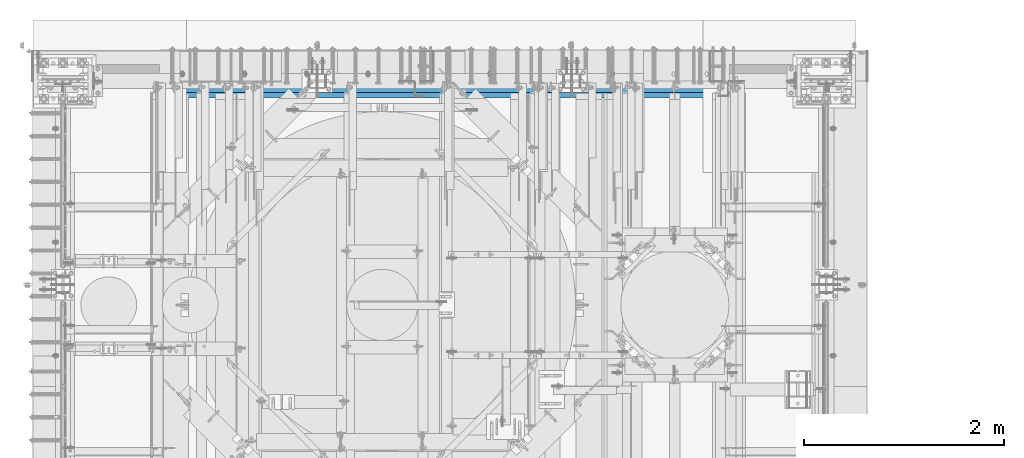
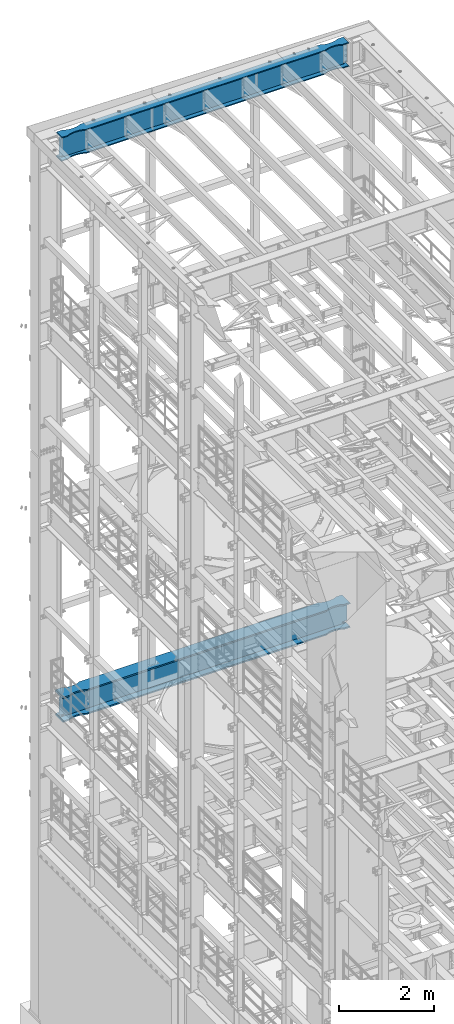
# One storey, part 1067 of 1876: 2 beams, 2 elements without a shape of their own.
"""IFC2X3 building model written with IfcOpenShell, lengths in millimetres."""

import ifcopenshell
import ifcopenshell.guid

model = None  # the IFC model being written
_history = None  # IfcOwnerHistory: only IFC2X3 demands one
_inside = {}  # id of a spatial element -> (the spatial element, [elements in it])
_under = {}  # id of a project, library or spatial element -> (it, [spatial elements below it])
_declared = {}  # id of a project -> (the project, [libraries it declares])
_typed = {}  # id of a type object -> (the type object, [elements of that type])
_made_of = {}  # id of a material, layer set ... -> (it, [elements and type objects made of it])


def new_model(schema):
    """Start an empty IFC model of exactly this schema.

    Asked for "IFC4X3", IfcOpenShell would pick the latest addendum, in which some entities
    have other attributes; the version numbers below select the first issue.
    IFC2X3 requires an IfcOwnerHistory on every rooted entity: one is made here for all.
    """
    global model, _history
    if schema == "IFC4X3":
        model = ifcopenshell.file(schema_version=(4, 3, 0, 0))
    else:
        model = ifcopenshell.file(schema=schema)
    _inside.clear()
    _under.clear()
    _declared.clear()
    _typed.clear()
    _made_of.clear()
    _history = None
    if model.schema == "IFC2X3":
        org = make("IfcOrganization", Name="unknown")
        user = make(
            "IfcPersonAndOrganization",
            ThePerson=make("IfcPerson", FamilyName="unknown"),
            TheOrganization=org,
        )
        app = make(
            "IfcApplication",
            ApplicationDeveloper=org,
            Version="unknown",
            ApplicationFullName="unknown",
            ApplicationIdentifier="unknown",
        )
        _history = make(
            "IfcOwnerHistory",
            OwningUser=user,
            OwningApplication=app,
            ChangeAction="ADDED",
            CreationDate=0,
        )
    return model


def make(cls, **values):
    """One entity of the class cls with the attributes given. An attribute that is None is left unset."""
    return model.create_entity(
        cls, **{name: value for name, value in values.items() if value is not None}
    )


def rooted(cls, **values):
    """An entity with a GlobalId (a new one), such as an element, a storey or a relation."""
    return make(cls, GlobalId=ifcopenshell.guid.new(), OwnerHistory=_history, **values)


def si_unit(unit_type, name, prefix=None):
    """IfcSIUnit, for example si_unit("LENGTHUNIT", "METRE", prefix="MILLI")."""
    return make("IfcSIUnit", UnitType=unit_type, Prefix=prefix, Name=name)


def assignment(units):
    """IfcUnitAssignment: the units of a project."""
    return None if units is None else make("IfcUnitAssignment", Units=units)


def point(xyz):
    """IfcCartesianPoint."""
    return None if xyz is None else make("IfcCartesianPoint", Coordinates=xyz)


def direction(xyz):
    """IfcDirection."""
    return None if xyz is None else make("IfcDirection", DirectionRatios=xyz)


def frame(location, z_axis=None, x_axis=None):
    """IfcAxis2Placement3D, a coordinate frame: its origin and axes. An axis left out is left unset."""
    return make(
        "IfcAxis2Placement3D",
        Location=point(location),
        Axis=direction(z_axis),
        RefDirection=direction(x_axis),
    )


def origin_with_axes():
    """The frame at (0, 0, 0) with the z axis (0, 0, 1) and the x axis (1, 0, 0) written out."""
    return frame((0.0, 0.0, 0.0), z_axis=(0.0, 0.0, 1.0), x_axis=(1.0, 0.0, 0.0))


def place(relative_to, where):
    """IfcLocalPlacement: puts the frame where relative to a parent placement (None: the world)."""
    return make(
        "IfcLocalPlacement", PlacementRelTo=relative_to, RelativePlacement=where
    )


def context(
    kind, dimensions, precision=None, world=None, true_north=None, identifier=None
):
    """IfcGeometricRepresentationContext, for example the 3D "Model" context."""
    return make(
        "IfcGeometricRepresentationContext",
        ContextIdentifier=identifier,
        ContextType=kind,
        CoordinateSpaceDimension=dimensions,
        Precision=precision,
        WorldCoordinateSystem=world,
        TrueNorth=true_north,
    )


def subcontext(parent, identifier, kind, view, scale=None):
    """IfcGeometricRepresentationSubContext, for example "Body" below "Model"."""
    return make(
        "IfcGeometricRepresentationSubContext",
        ContextIdentifier=identifier,
        ContextType=kind,
        ParentContext=parent,
        TargetScale=scale,
        TargetView=view,
    )


def project(units=None, contexts=None):
    """IfcProject with its units and contexts."""
    return rooted(
        "IfcProject",
        Name="project",
        RepresentationContexts=contexts,
        UnitsInContext=assignment(units),
    )


def spatial(cls, under=None, at=None, **own):
    """A site, building, storey or space (cls), placed at a placement, below another one or the project."""
    s = rooted(cls, ObjectPlacement=at, **own)
    if under is not None:
        _under.setdefault(under.id(), (under, []))[1].append(s)
    return s


def faces_of(points, faces, orient=None, outer=None):
    """IfcFace entities. A face is a list of loops; a loop is a list of indices into points, from 0.

    orient and outer hold one flag for each loop. By default every Orientation is true, the
    first loop of a face is its IfcFaceOuterBound and the others are IfcFaceBound.
    """
    made = []
    for i, loops in enumerate(faces):
        bounds = []
        for j, loop in enumerate(loops):
            is_outer = j == 0 if outer is None else outer[i][j]
            bounds.append(
                make(
                    "IfcFaceOuterBound" if is_outer else "IfcFaceBound",
                    Bound=make("IfcPolyLoop", Polygon=[points[k] for k in loop]),
                    Orientation=True if orient is None else orient[i][j],
                )
            )
        made.append(make("IfcFace", Bounds=bounds))
    return made


def faceted_brep(points, faces, orient=None, outer=None, voids=None):
    """IfcFacetedBrep: a solid bounded by flat faces; with voids (closed shells), ...WithVoids."""
    shared = [point(p) for p in points]
    hull = make("IfcClosedShell", CfsFaces=faces_of(shared, faces, orient, outer))
    if voids is None:
        return make("IfcFacetedBrep", Outer=hull)
    return make(
        "IfcFacetedBrepWithVoids",
        Outer=hull,
        Voids=[
            make(cls, CfsFaces=faces_of(shared, fs, o, b)) for cls, fs, o, b in voids
        ],
    )


def shape(context_of_items, identifier, shape_type, items):
    """IfcShapeRepresentation: the items that make up one representation, for example the "Body"."""
    return make(
        "IfcShapeRepresentation",
        ContextOfItems=context_of_items,
        RepresentationIdentifier=identifier,
        RepresentationType=shape_type,
        Items=items,
    )


def material(Name=None, Category=None):
    """IfcMaterial."""
    return make("IfcMaterial", Name=Name, Category=Category)


def made_of(thing, what):
    """Note that an element or type object is made of a material, layer set ...; save() writes the relation."""
    if what is not None:
        _made_of.setdefault(what.id(), (what, []))[1].append(thing)
    return thing


def type_object(cls, material=None, **own):
    """A type object (cls), such as IfcWallType, which elements share."""
    return made_of(rooted(cls, **own), material)


def element(
    cls,
    number,
    at=None,
    inside=None,
    cuts=None,
    type_object=None,
    material=None,
    context=None,
    identifier="Body",
    shape_type=None,
    held_by="IfcProductDefinitionShape",
    body=None,
    shapes=None,
    **own,
):
    """One element of the class cls, such as IfcWall. Its Tag is "e" and its number.

    at: its placement. inside: the storey or other place that contains it. cuts: it is an
    opening in that element (IfcRelVoidsElement). A single representation is given by context,
    identifier, shape_type and body (its items); several are given by shapes. held_by: the class
    of the entity that holds the representations. save() writes the other relations.
    """
    e = rooted(cls, Tag="e%d" % number, ObjectPlacement=at, **own)
    if body is not None:
        shapes = [shape(context, identifier, shape_type, body)]
    if shapes is not None:
        e.Representation = make(held_by, Representations=shapes)
    if inside is not None:
        _inside.setdefault(inside.id(), (inside, []))[1].append(e)
    if cuts is not None:
        rooted(
            "IfcRelVoidsElement", RelatingBuildingElement=cuts, RelatedOpeningElement=e
        )
    if type_object is not None:
        _typed.setdefault(type_object.id(), (type_object, []))[1].append(e)
    return made_of(e, material)


def aggregate(whole, parts):
    """IfcRelAggregates: a whole, such as a stair, and the parts it consists of."""
    return rooted("IfcRelAggregates", RelatingObject=whole, RelatedObjects=parts)


def save(model, path):
    """Write the relations noted so far, then the file.

    IfcRelAggregates (storeys below a building ...), IfcRelContainedInSpatialStructure (elements
    in a storey), IfcRelDefinesByType, IfcRelAssociatesMaterial and IfcRelDeclares: one each for
    every whole, place, type object, material and project.
    """
    for whole, parts in _under.values():
        aggregate(whole, parts)
    for where, things in _inside.values():
        rooted(
            "IfcRelContainedInSpatialStructure",
            RelatedElements=things,
            RelatingStructure=where,
        )
    for kind, things in _typed.values():
        rooted("IfcRelDefinesByType", RelatedObjects=things, RelatingType=kind)
    for what, things in _made_of.values():
        rooted("IfcRelAssociatesMaterial", RelatedObjects=things, RelatingMaterial=what)
    for by, libraries in _declared.values():
        rooted("IfcRelDeclares", RelatingContext=by, RelatedDefinitions=libraries)
    model.write(path)


model = new_model("IFC2X3")

# Units and contexts
model_context = context("Model", 3, precision=1e-05, world=origin_with_axes())
body_context = subcontext(model_context, "Body", "Model", "MODEL_VIEW")
ifc_project = project(units=[si_unit("LENGTHUNIT", "METRE", prefix="MILLI"), si_unit("AREAUNIT", "SQUARE_METRE"), si_unit("VOLUMEUNIT", "CUBIC_METRE"), si_unit("MASSUNIT", "GRAM", prefix="KILO"), si_unit("TIMEUNIT", "SECOND"), si_unit("PLANEANGLEUNIT", "RADIAN"), si_unit("SOLIDANGLEUNIT", "STERADIAN"), si_unit("THERMODYNAMICTEMPERATUREUNIT", "DEGREE_CELSIUS"), si_unit("LUMINOUSINTENSITYUNIT", "LUMEN")], contexts=[model_context])

# Site, building, storey
site_placement = place(None, origin_with_axes())
site = spatial("IfcSite", under=ifc_project, at=site_placement, CompositionType="ELEMENT")
building_placement = place(site_placement, origin_with_axes())
building = spatial("IfcBuilding", under=site, at=building_placement, Name="Undefined", CompositionType="ELEMENT")
storey_placement = place(building_placement, origin_with_axes())
storey = spatial("IfcBuildingStorey", under=building, at=storey_placement, Name="Undefined", CompositionType="ELEMENT", Elevation=0.0)

# Assembly, beam
assembly_1_placement = place(storey_placement, origin_with_axes())
assembly_1 = element("IfcElementAssembly", 1, at=assembly_1_placement, inside=storey, Name="BEAM", AssemblyPlace="NOTDEFINED", PredefinedType="RIGID_FRAME")
ifc_material = material(Name="STEEL/A992")
beam_type_1 = type_object("IfcBeamType", Name="W24X103", PredefinedType="NOTDEFINED")
beam_1_placement = place(assembly_1_placement, frame((0.0, 13716.0, 22244.05), z_axis=(0.0, 0.0, 1.0), x_axis=(1.0, 0.0, 0.0)))
beam_1 = element("IfcBeam", 2, at=beam_1_placement, type_object=beam_type_1, material=ifc_material, Name="BEAM", ObjectType="W24X103", context=body_context, shape_type="Brep", body=[
    faceted_brep([(7310.4375, 7.14374999999927, 250.825000000001), (7318.375, -7.14374999999927, 250.825000000001), (7318.375, -7.14374999999927, -250.825000000001), (7310.4375, 7.14374999999927, -250.825000000001), (301.625, -7.14374999999927, 250.825000000001), (309.5625, 7.14374999999927, 250.825000000001), (309.5625, 7.14374999999927, -250.825000000001), (301.625, -7.14374999999927, -250.825000000001), (7031.26184334843, -69.8863852197028, -285.75), (7031.26184334843, -69.8863852197028, -311.150000000001), (7113.70085269938, -88.8999885500325, -311.150000000001), (7113.70085269938, -88.8999885500325, -285.75), (6946.89999522536, -63.4999969110422, -285.75), (6946.89999522536, -63.4999969110422, -311.150000000001), (6862.53814723751, -69.886387005964, -285.75), (6862.53814723751, -69.886387005964, -311.150000000001), (6780.09913828916, -88.8999920818405, -285.75), (6780.09913828916, -88.8999920818405, -311.150000000001), (6730.99999123786, -114.3, -285.75), (6730.99999123786, -114.3, -311.150000000001), (889.000008761879, -114.300009625518, -285.75), (889.000008761879, -114.3, -311.150000000001), (6730.99999123786, -114.3, 285.75), (6730.99999123786, -114.3, 311.150000000001), (889.000008761879, -114.300009625518, 311.150000000001), (889.000008761879, -114.3, 285.75), (6780.09913828916, -88.8999920818405, 285.75), (6780.09913828916, -88.8999920818405, 311.150000000001), (6862.53814723751, -69.886387005964, 285.75), (6862.53814723751, -69.886387005964, 311.150000000001), (6946.89999522536, -63.4999969110422, 285.75), (6946.89999522536, -63.4999969110422, 311.150000000001), (7031.26184334843, -69.8863852197028, 285.75), (7031.26184334843, -69.8863852197028, 311.150000000001), (7113.70085269938, -88.8999885500325, 285.75), (7113.70085269938, -88.8999885500325, 311.150000000001), (7162.79999999982, -114.299985144468, 311.150000000001), (7162.79999999982, -114.3, 285.75), (7318.375, -114.3, 285.75), (7303.71041369173, -114.299998599709, 311.150000000001), (7269.91500317383, -7.14375000000018, -285.35299987793), (7269.91500317383, 7.14375000000018, -285.35299987793), (7234.44274885072, 7.14375000000018, -269.000062630286), (7234.44274885072, -7.14375000000018, -269.000062630286), (7230.55254094452, 7.14375000000018, -265.703842989446), (7230.55254094452, -7.14375000000018, -265.703842989446), (7228.91987519741, 7.14375000000018, -260.873399528195), (7228.91987519741, -7.14375000000018, -260.873399528195), (7230.01261637614, 7.14375000000018, -255.89296800167), (7230.01261637614, -7.14375000000018, -255.89296800167), (7233.51762316711, 7.14375000000018, -252.189765486371), (7233.51762316711, -7.14375000000018, -252.189765486371), (7238.43048349907, 7.14375000000018, -250.825000000001), (7238.43048349907, -7.14375000000018, -250.825000000001), (7239.26548546451, 7.14375000000018, 250.825000000001), (7239.26548546451, -7.14375000000018, 250.825000000001), (7234.35262519576, 7.14375000000018, 252.189765448315), (7234.35262519576, -7.14375000000018, 252.189765448315), (7230.84761841062, 7.14375000000018, 255.892967871263), (7230.84761841062, -7.14375000000018, 255.892967871263), (7229.75487715069, 7.14375000000018, 260.873399307191), (7229.75487715069, -7.14375000000018, 260.873399307191), (7231.38754274408, 7.14375000000018, 265.703842745359), (7231.38754274408, -7.14375000000018, 265.703842745359), (7235.27775048114, 7.14375000000018, 269.000062475843), (7235.27775048114, -7.14375000000018, 269.000062475843), (7270.75000152588, 7.14375000000018, 285.35299987793), (7270.75000152588, -7.14375000000018, 285.35299987793), (7318.375, 7.14375000000018, 285.35299987793), (7318.375, -7.14375000000018, 285.35299987793), (7318.375, 7.14375000000018, 285.75), (7318.375, -7.14375000000018, 285.75), (6730.99999123786, 114.3, 311.150000000001), (6730.99999123786, 114.3, 285.75), (889.000008761879, 114.3, 285.75), (889.000008761879, 114.299990374482, 311.150000000001), (6780.09913828916, 88.9000064541397, 311.150000000001), (6780.09913828916, 88.9000064541397, 285.75), (6862.53814723751, 69.8864013782631, 311.150000000001), (6862.53814723751, 69.8864013782631, 285.75), (6946.89999522536, 63.5000112833413, 311.150000000001), (6946.89999522536, 63.5000112833413, 285.75), (7031.26184334843, 69.8863995920019, 311.150000000001), (7031.26184334843, 69.8863995920019, 285.75), (7113.70085269938, 88.9000029223316, 311.150000000001), (7113.70085269938, 88.9000029223316, 285.75), (7162.79999999982, 114.299999516767, 311.150000000001), (7162.79999999982, 114.3, 285.75), (7303.71041369173, 114.29999995445, 311.150000000001), (7318.375, 114.3, 285.75), (301.625, 7.14375000000018, 285.75), (301.625, 114.3, 285.75), (457.200000000009, 114.3, 285.75), (506.299147300449, 88.899986110664, 285.75), (588.738156651386, 69.8863827803343, 285.75), (673.100004774441, 63.4999944716737, 285.75), (757.461852762268, 69.8863845665956, 285.75), (839.9008617106, 88.8999896424721, 285.75), (457.200000000009, 114.3, 311.150000000001), (316.289586308271, 114.3, 311.150000000001), (506.299147300449, 88.899986110664, 311.150000000001), (588.738156651386, 69.8863827803343, 311.150000000001), (673.100004774441, 63.4999944716737, 311.150000000001), (757.461852762268, 69.8863845665956, 311.150000000001), (839.9008617106, 88.8999896424721, 311.150000000001), (316.289586308271, -114.3, 311.150000000001), (457.200000000009, -114.3, 311.150000000001), (506.299147300449, -88.9000053617001, 311.150000000001), (588.738156651386, -69.8864020313704, 311.150000000001), (673.100004774441, -63.5000137227098, 311.150000000001), (757.461852762268, -69.8864038176316, 311.150000000001), (839.9008617106, -88.9000088935081, 311.150000000001), (457.200000000009, -114.3, 285.75), (301.625, -114.3, 285.75), (506.299147300449, -88.9000053617001, 285.75), (588.738156651386, -69.8864020313704, 285.75), (673.100004774441, -63.5000137227098, 285.75), (757.461852762268, -69.8864038176316, 285.75), (839.9008617106, -88.9000088935081, 285.75), (301.625, -7.14375000000018, 285.75), (301.625, 7.14375000000018, 285.35299987793), (301.625, -7.14375000000018, 285.35299987793), (349.249998474121, 7.14375000000018, 285.35299987793), (349.249998474121, -7.14375000000018, 285.35299987793), (384.722249518856, 7.14375000000018, 269.000062475843), (384.722249518856, -7.14375000000018, 269.000062475843), (388.612457255921, 7.14375000000018, 265.703842745359), (388.612457255921, -7.14375000000018, 265.703842745359), (390.245122849314, 7.14375000000018, 260.873399307191), (390.245122849314, -7.14375000000018, 260.873399307191), (389.152381589376, 7.14375000000018, 255.892967871263), (389.152381589376, -7.14375000000018, 255.892967871263), (385.647374804242, 7.14375000000018, 252.189765448315), (385.647374804242, -7.14375000000018, 252.189765448315), (380.734514535493, 7.14375000000018, 250.825000000001), (380.734514535493, -7.14375000000018, 250.825000000001), (381.56951650093, 7.14375000000018, -250.825000000001), (381.56951650093, -7.14375000000018, -250.825000000001), (386.482376832887, 7.14375000000018, -252.189765486371), (386.482376832887, -7.14375000000018, -252.189765486371), (389.98738362386, 7.14375000000018, -255.89296800167), (389.98738362386, -7.14375000000018, -255.89296800167), (391.080124802588, 7.14375000000018, -260.873399528195), (391.080124802588, -7.14375000000018, -260.873399528195), (389.447459055476, 7.14375000000018, -265.703842989446), (389.447459055476, -7.14375000000018, -265.703842989446), (385.557251149282, 7.14375000000018, -269.000062630286), (385.557251149282, -7.14375000000018, -269.000062630286), (350.084996826172, 7.14375000000018, -285.35299987793), (350.084996826172, -7.14375000000018, -285.35299987793), (316.518799385621, 7.14375000000018, -285.35299987793), (316.518799385621, -7.14375000000018, -285.35299987793), (316.28959905754, -7.14375000000018, -285.75), (7303.71040094246, -7.14375000000018, -285.75), (7303.48120061438, -7.14375000000018, -285.35299987793), (7303.48120061438, 7.14375000000018, -285.35299987793), (7303.71040094246, 7.14375000000018, -285.75), (316.28959905754, 7.14375000000018, -285.75), (316.28959905754, 114.3, -285.75), (301.625, 114.3, -311.150000000001), (301.625, -114.3, -311.150000000001), (316.28959905754, -114.3, -285.75), (457.200000000009, -114.3, -311.150000000001), (457.200000000009, -114.3, -285.75), (506.299147300449, -88.9000053617001, -311.150000000001), (506.299147300449, -88.9000053617001, -285.75), (588.738156651386, -69.8864020313704, -311.150000000001), (588.738156651386, -69.8864020313704, -285.75), (673.100004774441, -63.5000137227098, -311.150000000001), (673.100004774441, -63.5000137227098, -285.75), (757.461852762268, -69.8864038176316, -311.150000000001), (757.461852762268, -69.8864038176316, -285.75), (839.9008617106, -88.9000088935081, -311.150000000001), (839.9008617106, -88.9000088935081, -285.75), (7162.79999999982, -114.299985144468, -285.75), (7303.71040094246, -114.299998599708, -285.75), (7318.375, -114.3, -311.150000000001), (7318.375, 114.3, -311.150000000001), (7303.71040094246, 114.29999995445, -285.75), (7162.79999999982, 114.3, -311.150000000001), (7162.79999999982, 114.299999516767, -285.75), (7113.70085269938, 88.9000029223316, -311.150000000001), (7113.70085269938, 88.9000029223316, -285.75), (7031.26184334843, 69.8863995920019, -311.150000000001), (7031.26184334843, 69.8863995920019, -285.75), (6946.89999522536, 63.5000112833413, -311.150000000001), (6946.89999522536, 63.5000112833413, -285.75), (6862.53814723751, 69.8864013782631, -311.150000000001), (6862.53814723751, 69.8864013782631, -285.75), (6780.09913828916, 88.9000064541397, -311.150000000001), (6780.09913828916, 88.9000064541397, -285.75), (6730.99999123786, 114.3, -311.150000000001), (6730.99999123786, 114.3, -285.75), (889.000008761879, 114.3, -311.150000000001), (889.000008761879, 114.299990374482, -285.75), (839.9008617106, 88.8999896424721, -285.75), (757.461852762268, 69.8863845665956, -285.75), (673.100004774441, 63.4999944716737, -285.75), (588.738156651386, 69.8863827803343, -285.75), (506.299147300449, 88.899986110664, -285.75), (457.200000000009, 114.3, -285.75), (457.200000000009, 114.3, -311.150000000001), (506.299147300449, 88.899986110664, -311.150000000001), (588.738156651386, 69.8863827803343, -311.150000000001), (673.100004774441, 63.4999944716737, -311.150000000001), (757.461852762268, 69.8863845665956, -311.150000000001), (839.9008617106, 88.8999896424721, -311.150000000001), (7162.79999999982, -114.3, -311.150000000001)], [[[0, 1, 2, 3]], [[4, 5, 6, 7]], [[8, 9, 10, 11]], [[12, 13, 9, 8]], [[14, 15, 13, 12]], [[16, 17, 15, 14]], [[18, 19, 17, 16]], [[19, 18, 20, 21]], [[22, 23, 24, 25]], [[23, 22, 26, 27]], [[27, 26, 28, 29]], [[29, 28, 30, 31]], [[31, 30, 32, 33]], [[33, 32, 34, 35]], [[36, 35, 34, 37]], [[36, 37, 38, 39]], [[40, 41, 42, 43]], [[43, 42, 44, 45]], [[45, 44, 46, 47]], [[47, 46, 48, 49]], [[49, 48, 50, 51]], [[51, 50, 52, 53]], [[53, 52, 3, 2]], [[54, 55, 1, 0]], [[55, 54, 56, 57]], [[57, 56, 58, 59]], [[59, 58, 60, 61]], [[61, 60, 62, 63]], [[63, 62, 64, 65]], [[65, 64, 66, 67]], [[67, 66, 68, 69]], [[69, 68, 70, 71]], [[72, 73, 74, 75]], [[76, 77, 73, 72]], [[78, 79, 77, 76]], [[80, 81, 79, 78]], [[82, 83, 81, 80]], [[84, 85, 83, 82]], [[86, 87, 85, 84]], [[87, 86, 88, 89]], [[38, 71, 70, 89, 88, 39]], [[90, 91, 92, 93, 94, 95, 96, 97, 74, 73, 77, 79, 81, 83, 85, 87, 89, 70]], [[98, 92, 91, 99]], [[100, 93, 92, 98]], [[101, 94, 93, 100]], [[102, 95, 94, 101]], [[103, 96, 95, 102]], [[104, 97, 96, 103]], [[75, 74, 97, 104]], [[86, 84, 82, 80, 78, 76, 72, 75, 104, 103, 102, 101, 100, 98, 99, 105, 106, 107, 108, 109, 110, 111, 24, 23, 27, 29, 31, 33, 35, 36, 39, 88]], [[112, 106, 105, 113]], [[106, 112, 114, 107]], [[107, 114, 115, 108]], [[108, 115, 116, 109]], [[109, 116, 117, 110]], [[110, 117, 118, 111]], [[24, 111, 118, 25]], [[37, 34, 32, 30, 28, 26, 22, 25, 118, 117, 116, 115, 114, 112, 113, 119, 71, 38]], [[105, 99, 91, 90, 119, 113]], [[120, 121, 119, 90]], [[122, 123, 121, 120]], [[123, 122, 124, 125]], [[125, 124, 126, 127]], [[127, 126, 128, 129]], [[129, 128, 130, 131]], [[131, 130, 132, 133]], [[133, 132, 134, 135]], [[135, 134, 5, 4]], [[136, 137, 7, 6]], [[137, 136, 138, 139]], [[139, 138, 140, 141]], [[141, 140, 142, 143]], [[143, 142, 144, 145]], [[145, 144, 146, 147]], [[147, 146, 148, 149]], [[149, 148, 150, 151]], [[40, 43, 45, 47, 49, 51, 53, 2, 1, 55, 57, 59, 61, 63, 65, 67, 69, 71, 119, 121, 123, 125, 127, 129, 131, 133, 135, 4, 7, 137, 139, 141, 143, 145, 147, 149, 151, 152, 153, 154]], [[41, 40, 154, 155]], [[52, 50, 48, 46, 44, 42, 41, 155, 156, 157, 150, 148, 146, 144, 142, 140, 138, 136, 6, 5, 134, 132, 130, 128, 126, 124, 122, 120, 90, 70, 68, 66, 64, 62, 60, 58, 56, 54, 0, 3]], [[151, 150, 157, 158, 159, 160, 161, 152]], [[162, 163, 161, 160]], [[163, 162, 164, 165]], [[165, 164, 166, 167]], [[167, 166, 168, 169]], [[169, 168, 170, 171]], [[171, 170, 172, 173]], [[20, 173, 172, 21]], [[152, 161, 163, 165, 167, 169, 171, 173, 20, 18, 16, 14, 12, 8, 11, 174, 175, 153]], [[176, 177, 178, 156, 155, 154, 153, 175]], [[179, 180, 178, 177]], [[180, 179, 181, 182]], [[182, 181, 183, 184]], [[184, 183, 185, 186]], [[186, 185, 187, 188]], [[188, 187, 189, 190]], [[190, 189, 191, 192]], [[192, 191, 193, 194]], [[180, 182, 184, 186, 188, 190, 192, 194, 195, 196, 197, 198, 199, 200, 158, 157, 156, 178]], [[200, 201, 159, 158]], [[199, 202, 201, 200]], [[198, 203, 202, 199]], [[197, 204, 203, 198]], [[196, 205, 204, 197]], [[195, 206, 205, 196]], [[194, 193, 206, 195]], [[207, 10, 9, 13, 15, 17, 19, 21, 172, 170, 168, 166, 164, 162, 160, 159, 201, 202, 203, 204, 205, 206, 193, 191, 189, 187, 185, 183, 181, 179, 177, 176]], [[174, 11, 10, 207]], [[174, 207, 176, 175]]]),
])
aggregate(assembly_1, [beam_1])

assembly_2_placement = place(storey_placement, origin_with_axes())
assembly_2 = element("IfcElementAssembly", 3, at=assembly_2_placement, inside=storey, Name="BEAM", AssemblyPlace="NOTDEFINED", PredefinedType="RIGID_FRAME")
beam_type_2 = type_object("IfcBeamType", Name="W24X192", PredefinedType="NOTDEFINED")
beam_2_placement = place(assembly_2_placement, frame((0.0, 13716.0, 7829.55), z_axis=(0.0, 0.0, 1.0), x_axis=(1.0, 0.0, 0.0)))
beam_2 = element("IfcBeam", 4, at=beam_2_placement, type_object=beam_type_2, material=ifc_material, Name="BEAM", ObjectType="W24X192", context=body_context, shape_type="Brep", body=[
    faceted_brep([(7305.675, 10.3187500000004, 234.9495), (7318.375, -10.3187500000004, 234.9495), (7318.375, -10.3187500000004, -234.9495), (7305.675, 10.3187500000004, -234.9495), (314.325, 10.3187500000004, -234.9495), (301.625, -10.3187500000004, -234.9495), (301.625, -10.3187500000004, 234.9495), (314.325, 10.3187500000004, 234.9495), (6787.91106783742, 137.326657821507, 323.85), (6787.91106783742, 137.326657821507, 287.3375), (6731.00000871489, 165.1, 287.3375), (6731.00000871489, 165.100000403941, 323.85), (6866.57611029489, 120.086540015548, 323.85), (6866.57611029489, 120.086540015548, 287.3375), (6946.89999542258, 114.300000048446, 323.85), (6946.89999542258, 114.300000048446, 287.3375), (7027.22388047199, 120.086541102203, 323.85), (7027.22388047199, 120.086541102203, 287.3375), (7104.96083834654, 137.123262325114, 323.85), (7104.96083834654, 137.123262325114, 287.3375), (7105.41939640416, 137.238170811695, 323.85), (7105.41939640416, 137.238170811695, 287.3375), (7105.87030058721, 137.380173875744, 323.85), (7105.87030058721, 137.380173875744, 287.3375), (7106.31195150567, 137.548767822031, 323.85), (7106.31195150567, 137.548767822031, 287.3375), (7106.74278259149, 137.743354635527, 323.85), (7106.74278259149, 137.743354635527, 287.3375), (7162.79999999997, 165.100001147153, 323.85), (7162.79999999997, 165.1, 287.3375), (6787.91106783742, 137.326657821507, -287.3375), (6787.91106783742, 137.326657821507, -323.85), (6731.00000871489, 165.1, -323.85), (6731.00000871489, 165.100000403941, -287.3375), (6866.57611029489, 120.086540015548, -287.3375), (6866.57611029489, 120.086540015548, -323.85), (6946.89999542258, 114.300000048446, -287.3375), (6946.89999542258, 114.300000048446, -323.85), (7027.22388047199, 120.086541102203, -287.3375), (7027.22388047199, 120.086541102203, -323.85), (7104.96083834654, 137.123262325114, -287.3375), (7104.96083834654, 137.123262325114, -323.85), (7105.41939640416, 137.238170811695, -287.3375), (7105.41939640416, 137.238170811695, -323.85), (7105.87030058721, 137.380173875744, -287.3375), (7105.87030058721, 137.380173875744, -323.85), (7106.31195150567, 137.548767822031, -287.3375), (7106.31195150567, 137.548767822031, -323.85), (7106.74278259149, 137.743354635527, -287.3375), (7106.74278259149, 137.743354635527, -323.85), (7162.79999999997, 165.100001147153, -287.3375), (7162.79999999997, 165.1, -323.85), (7162.79999999997, -165.100001147153, -287.3375), (7162.79999999997, -165.1, -323.85), (7318.375, -165.1, -323.85), (7297.29440923203, -165.10000015544, -287.3375), (7162.79999999997, -165.100001147153, 323.85), (7162.79999999997, -165.1, 287.3375), (7318.375, -165.1, 287.3375), (7297.29441686758, -165.10000015544, 323.85), (7273.02300067138, -10.3187500000004, -286.94050112915), (7273.02300067138, 10.3187500000004, -286.94050112915), (7199.93843450559, 10.3187500000004, -253.118738544442), (7199.93843450559, -10.3187500000004, -253.118738544442), (7196.05459563403, 10.3187500000004, -249.819149292641), (7196.05459563403, -10.3187500000004, -249.819149292641), (7194.42771578867, 10.3187500000004, -244.98957834072), (7194.42771578867, -10.3187500000004, -244.98957834072), (7195.52351237729, 10.3187500000004, -240.012558806176), (7195.52351237729, -10.3187500000004, -240.012558806176), (7199.02829809953, 10.3187500000004, -236.312833052547), (7199.02829809953, -10.3187500000004, -236.312833052547), (7203.93877838141, 10.3187500000004, -234.9495), (7203.93877838141, -10.3187500000004, -234.9495), (7204.84078095454, 10.3187500000004, 234.9495), (7204.84078095454, -10.3187500000004, 234.9495), (7199.93030069379, 10.3187500000004, 236.312833039837), (7199.93030069379, -10.3187500000004, 236.312833039837), (7196.42551497352, 10.3187500000004, 240.012558762612), (7196.42551497352, -10.3187500000004, 240.012558762612), (7195.3297183578, 10.3187500000004, 244.989578266866), (7195.3297183578, -10.3187500000004, 244.989578266866), (7196.95659815183, 10.3187500000004, 249.819149211013), (7196.95659815183, -10.3187500000004, 249.819149211013), (7200.84043696685, 10.3187500000004, 253.118738492671), (7200.84043696685, -10.3187500000004, 253.118738492671), (7273.92500076294, 10.3187500000004, 286.94050112915), (7273.92500076294, -10.3187500000004, 286.94050112915), (7318.375, 10.3187500000004, 286.94050112915), (7318.375, -10.3187500000004, 286.94050112915), (7318.375, 10.3187500000004, 287.3375), (7318.375, -10.3187500000004, 287.3375), (7318.375, 165.1, 287.3375), (7297.29441686758, 165.10000015544, 323.85), (457.199999305522, 165.1, 323.85), (457.199999305522, 165.1, 287.3375), (301.625, 165.1, 287.3375), (322.705583132423, 165.1, 323.85), (513.257216713985, 137.743354635527, 323.85), (513.257216713985, 137.743354635527, 287.3375), (513.688047799806, 137.548767822031, 323.85), (513.688047799806, 137.548767822031, 287.3375), (514.12969871826, 137.380173875744, 323.85), (514.12969871826, 137.380173875744, 287.3375), (514.580602901315, 137.238170811695, 323.85), (514.580602901315, 137.238170811695, 287.3375), (515.039160958935, 137.123262325114, 323.85), (515.039160958935, 137.123262325114, 287.3375), (592.776118833464, 120.086541102203, 323.85), (592.776118833464, 120.086541102203, 287.3375), (673.100003882856, 114.300000048446, 323.85), (673.100003882856, 114.300000048446, 287.3375), (753.423889010533, 120.086540015548, 323.85), (753.423889010533, 120.086540015548, 287.3375), (832.088931467987, 137.326657821507, 323.85), (832.088931467987, 137.326657821507, 287.3375), (888.999990590519, 165.100004421514, 323.85), (888.999990590519, 165.1, 287.3375), (301.625, 10.3187500000004, 287.3375), (322.705583132423, -165.1, 323.85), (457.199999305522, -165.1, 323.85), (513.257216713985, -137.743354635527, 323.85), (513.688047799806, -137.548767822031, 323.85), (514.12969871826, -137.380173875744, 323.85), (514.580602901315, -137.238170811695, 323.85), (515.039160958935, -137.123262325114, 323.85), (592.776118833464, -120.086541102203, 323.85), (673.100003882856, -114.300000048446, 323.85), (753.423889010533, -120.086540015548, 323.85), (832.088931467987, -137.326657821507, 323.85), (888.999990590519, -165.100004421514, 323.85), (6731.00000871489, -165.100000403941, 323.85), (6787.91106783742, -137.326657821507, 323.85), (6866.57611029489, -120.086540015548, 323.85), (6946.89999542258, -114.300000048446, 323.85), (7027.22388047199, -120.086541102203, 323.85), (7104.96083834654, -137.123262325114, 323.85), (7105.41939640416, -137.238170811695, 323.85), (7105.87030058721, -137.380173875744, 323.85), (7106.31195150567, -137.548767822031, 323.85), (7106.74278259149, -137.743354635527, 323.85), (457.199999305522, -165.1, 287.3375), (301.625, -165.1, 287.3375), (513.257216713985, -137.743354635527, 287.3375), (513.688047799806, -137.548767822031, 287.3375), (514.12969871826, -137.380173875744, 287.3375), (514.580602901315, -137.238170811695, 287.3375), (515.039160958935, -137.123262325114, 287.3375), (592.776118833464, -120.086541102203, 287.3375), (673.100003882856, -114.300000048446, 287.3375), (753.423889010533, -120.086540015548, 287.3375), (832.088931467987, -137.326657821507, 287.3375), (888.999990590519, -165.1, 287.3375), (6731.00000871489, -165.1, 287.3375), (6787.91106783742, -137.326657821507, 287.3375), (6866.57611029489, -120.086540015548, 287.3375), (6946.89999542258, -114.300000048446, 287.3375), (7027.22388047199, -120.086541102203, 287.3375), (7104.96083834654, -137.123262325114, 287.3375), (7105.41939640416, -137.238170811695, 287.3375), (7105.87030058721, -137.380173875744, 287.3375), (7106.31195150567, -137.548767822031, 287.3375), (7106.74278259149, -137.743354635527, 287.3375), (301.625, -10.3187500000004, 287.3375), (301.625, 10.3187500000004, 286.94050112915), (301.625, -10.3187500000004, 286.94050112915), (346.074999237061, 10.3187500000004, 286.94050112915), (346.074999237061, -10.3187500000004, 286.94050112915), (419.159563033145, 10.3187500000004, 253.11873849267), (419.159563033145, -10.3187500000004, 253.11873849267), (423.043401848172, 10.3187500000004, 249.819149211012), (423.043401848172, -10.3187500000004, 249.819149211012), (424.670281642195, 10.3187500000004, 244.989578266865), (424.670281642195, -10.3187500000004, 244.989578266865), (423.574485026478, 10.3187500000004, 240.012558762611), (423.574485026478, -10.3187500000004, 240.012558762611), (420.069699306212, 10.3187500000004, 236.312833039836), (420.069699306212, -10.3187500000004, 236.312833039836), (415.15921904546, 10.3187500000004, 234.949499999999), (415.15921904546, -10.3187500000004, 234.949499999999), (416.061221618592, 10.3187500000004, -234.9495), (416.061221618592, -10.3187500000004, -234.9495), (420.97170190047, 10.3187500000004, -236.312833052547), (420.97170190047, -10.3187500000004, -236.312833052547), (424.476487622709, 10.3187500000004, -240.012558806176), (424.476487622709, -10.3187500000004, -240.012558806176), (425.572284211328, 10.3187500000004, -244.98957834072), (425.572284211328, -10.3187500000004, -244.98957834072), (423.945404365968, 10.3187500000004, -249.819149292641), (423.945404365968, -10.3187500000004, -249.819149292641), (420.061565494404, 10.3187500000004, -253.118738544442), (420.061565494404, -10.3187500000004, -253.118738544442), (346.976999328614, 10.3187500000004, -286.94050112915), (346.976999328614, -10.3187500000004, -286.94050112915), (322.934794701563, 10.3187500000004, -286.94050112915), (322.934794701563, -10.3187500000004, -286.94050112915), (322.705590767971, -10.3187500000004, -287.3375), (7297.29440923203, -10.3187500000004, -287.3375), (7297.06520529844, -10.3187500000004, -286.94050112915), (7297.06520529844, 10.3187500000004, -286.94050112915), (7297.29440923203, 10.3187500000004, -287.3375), (322.705590767971, 10.3187500000004, -287.3375), (888.999990590519, 165.100004421514, -287.337500000001), (888.999990590519, 165.1, -323.85), (832.088931467987, 137.326657821507, -323.85), (832.088931467987, 137.326657821507, -287.3375), (753.423889010533, 120.086540015548, -323.85), (753.423889010533, 120.086540015548, -287.3375), (673.100003882856, 114.300000048446, -323.85), (673.100003882856, 114.300000048446, -287.3375), (592.776118833464, 120.086541102203, -323.85), (592.776118833464, 120.086541102203, -287.3375), (515.039160958935, 137.123262325114, -323.85), (515.039160958935, 137.123262325114, -287.3375), (514.580602901315, 137.238170811695, -323.85), (514.580602901315, 137.238170811695, -287.3375), (514.12969871826, 137.380173875744, -323.85), (514.12969871826, 137.380173875744, -287.3375), (513.688047799806, 137.548767822031, -323.85), (513.688047799806, 137.548767822031, -287.3375), (513.257216713985, 137.743354635527, -323.85), (513.257216713985, 137.743354635527, -287.3375), (457.199999305522, 165.1, -323.85), (457.199999305522, 165.1, -287.3375), (301.625, 165.1, -323.85), (322.705590767972, 165.1, -287.3375), (301.625, -165.1, -323.85), (322.705590767972, -165.1, -287.3375), (457.199999305522, -165.1, -323.85), (457.199999305522, -165.1, -287.3375), (513.257216713985, -137.743354635527, -323.85), (513.257216713985, -137.743354635527, -287.3375), (513.688047799806, -137.548767822031, -323.85), (513.688047799806, -137.548767822031, -287.3375), (514.12969871826, -137.380173875744, -323.85), (514.12969871826, -137.380173875744, -287.3375), (514.580602901315, -137.238170811695, -323.85), (514.580602901315, -137.238170811695, -287.3375), (515.039160958935, -137.123262325114, -323.85), (515.039160958935, -137.123262325114, -287.3375), (592.776118833464, -120.086541102203, -323.85), (592.776118833464, -120.086541102203, -287.3375), (673.100003882856, -114.300000048446, -323.85), (673.100003882856, -114.300000048446, -287.3375), (753.423889010533, -120.086540015548, -323.85), (753.423889010533, -120.086540015548, -287.3375), (832.088931467987, -137.326657821507, -323.85), (832.088931467987, -137.326657821507, -287.3375), (888.999990590519, -165.100004421514, -287.3375), (888.999990590519, -165.1, -323.85), (6731.00000871489, -165.1, -323.85), (6731.00000871489, -165.100000403941, -287.3375), (6787.91106783742, -137.326657821507, -323.85), (6787.91106783742, -137.326657821507, -287.3375), (6866.57611029489, -120.086540015548, -323.85), (6866.57611029489, -120.086540015548, -287.3375), (6946.89999542258, -114.300000048446, -323.85), (6946.89999542258, -114.300000048446, -287.3375), (7027.22388047199, -120.086541102203, -323.85), (7027.22388047199, -120.086541102203, -287.3375), (7104.96083834654, -137.123262325114, -323.85), (7104.96083834654, -137.123262325114, -287.3375), (7105.41939640416, -137.238170811695, -323.85), (7105.41939640416, -137.238170811695, -287.3375), (7105.87030058721, -137.380173875744, -323.85), (7105.87030058721, -137.380173875744, -287.3375), (7106.31195150567, -137.548767822031, -323.85), (7106.31195150567, -137.548767822031, -287.3375), (7106.74278259149, -137.743354635527, -323.85), (7106.74278259149, -137.743354635527, -287.3375), (7318.375, 165.1, -323.85), (7297.29440923203, 165.10000015544, -287.3375)], [[[0, 1, 2, 3]], [[4, 5, 6, 7]], [[8, 9, 10, 11]], [[12, 13, 9, 8]], [[14, 15, 13, 12]], [[16, 17, 15, 14]], [[18, 19, 17, 16]], [[20, 21, 19, 18]], [[22, 23, 21, 20]], [[24, 25, 23, 22]], [[26, 27, 25, 24]], [[28, 29, 27, 26]], [[30, 31, 32, 33]], [[34, 35, 31, 30]], [[36, 37, 35, 34]], [[38, 39, 37, 36]], [[40, 41, 39, 38]], [[42, 43, 41, 40]], [[44, 45, 43, 42]], [[46, 47, 45, 44]], [[48, 49, 47, 46]], [[50, 51, 49, 48]], [[52, 53, 54, 55]], [[56, 57, 58, 59]], [[60, 61, 62, 63]], [[63, 62, 64, 65]], [[65, 64, 66, 67]], [[67, 66, 68, 69]], [[69, 68, 70, 71]], [[71, 70, 72, 73]], [[73, 72, 3, 2]], [[74, 75, 1, 0]], [[75, 74, 76, 77]], [[77, 76, 78, 79]], [[79, 78, 80, 81]], [[81, 80, 82, 83]], [[83, 82, 84, 85]], [[85, 84, 86, 87]], [[87, 86, 88, 89]], [[89, 88, 90, 91]], [[58, 91, 90, 92, 93, 59]], [[94, 95, 96, 97]], [[98, 99, 95, 94]], [[100, 101, 99, 98]], [[102, 103, 101, 100]], [[104, 105, 103, 102]], [[106, 107, 105, 104]], [[108, 109, 107, 106]], [[110, 111, 109, 108]], [[112, 113, 111, 110]], [[114, 115, 113, 112]], [[116, 117, 115, 114]], [[117, 116, 11, 10]], [[118, 96, 95, 99, 101, 103, 105, 107, 109, 111, 113, 115, 117, 10, 9, 13, 15, 17, 19, 21, 23, 25, 27, 29, 92, 90]], [[29, 28, 93, 92]], [[28, 26, 24, 22, 20, 18, 16, 14, 12, 8, 11, 116, 114, 112, 110, 108, 106, 104, 102, 100, 98, 94, 97, 119, 120, 121, 122, 123, 124, 125, 126, 127, 128, 129, 130, 131, 132, 133, 134, 135, 136, 137, 138, 139, 140, 56, 59, 93]], [[141, 120, 119, 142]], [[120, 141, 143, 121]], [[121, 143, 144, 122]], [[122, 144, 145, 123]], [[123, 145, 146, 124]], [[124, 146, 147, 125]], [[125, 147, 148, 126]], [[126, 148, 149, 127]], [[127, 149, 150, 128]], [[128, 150, 151, 129]], [[130, 129, 151, 152]], [[130, 152, 153, 131]], [[131, 153, 154, 132]], [[132, 154, 155, 133]], [[133, 155, 156, 134]], [[134, 156, 157, 135]], [[135, 157, 158, 136]], [[136, 158, 159, 137]], [[137, 159, 160, 138]], [[138, 160, 161, 139]], [[139, 161, 162, 140]], [[56, 140, 162, 57]], [[57, 162, 161, 160, 159, 158, 157, 156, 155, 154, 153, 152, 151, 150, 149, 148, 147, 146, 145, 144, 143, 141, 142, 163, 91, 58]], [[119, 97, 96, 118, 163, 142]], [[164, 165, 163, 118]], [[166, 167, 165, 164]], [[167, 166, 168, 169]], [[169, 168, 170, 171]], [[171, 170, 172, 173]], [[173, 172, 174, 175]], [[175, 174, 176, 177]], [[177, 176, 178, 179]], [[179, 178, 7, 6]], [[180, 181, 5, 4]], [[181, 180, 182, 183]], [[183, 182, 184, 185]], [[185, 184, 186, 187]], [[187, 186, 188, 189]], [[189, 188, 190, 191]], [[191, 190, 192, 193]], [[193, 192, 194, 195]], [[60, 63, 65, 67, 69, 71, 73, 2, 1, 75, 77, 79, 81, 83, 85, 87, 89, 91, 163, 165, 167, 169, 171, 173, 175, 177, 179, 6, 5, 181, 183, 185, 187, 189, 191, 193, 195, 196, 197, 198]], [[61, 60, 198, 199]], [[72, 70, 68, 66, 64, 62, 61, 199, 200, 201, 194, 192, 190, 188, 186, 184, 182, 180, 4, 7, 178, 176, 174, 172, 170, 168, 166, 164, 118, 90, 88, 86, 84, 82, 80, 78, 76, 74, 0, 3]], [[202, 203, 204, 205]], [[205, 204, 206, 207]], [[207, 206, 208, 209]], [[209, 208, 210, 211]], [[211, 210, 212, 213]], [[213, 212, 214, 215]], [[215, 214, 216, 217]], [[217, 216, 218, 219]], [[219, 218, 220, 221]], [[221, 220, 222, 223]], [[223, 222, 224, 225]], [[195, 194, 201, 225, 224, 226, 227, 196]], [[228, 229, 227, 226]], [[229, 228, 230, 231]], [[231, 230, 232, 233]], [[233, 232, 234, 235]], [[235, 234, 236, 237]], [[237, 236, 238, 239]], [[239, 238, 240, 241]], [[241, 240, 242, 243]], [[243, 242, 244, 245]], [[245, 244, 246, 247]], [[248, 247, 246, 249]], [[248, 249, 250, 251]], [[251, 250, 252, 253]], [[253, 252, 254, 255]], [[255, 254, 256, 257]], [[257, 256, 258, 259]], [[259, 258, 260, 261]], [[261, 260, 262, 263]], [[263, 262, 264, 265]], [[265, 264, 266, 267]], [[267, 266, 268, 269]], [[52, 269, 268, 53]], [[196, 227, 229, 231, 233, 235, 237, 239, 241, 243, 245, 247, 248, 251, 253, 255, 257, 259, 261, 263, 265, 267, 269, 52, 55, 197]], [[54, 270, 271, 200, 199, 198, 197, 55]], [[50, 48, 46, 44, 42, 40, 38, 36, 34, 30, 33, 202, 205, 207, 209, 211, 213, 215, 217, 219, 221, 223, 225, 201, 200, 271]], [[203, 202, 33, 32]], [[53, 268, 266, 264, 262, 260, 258, 256, 254, 252, 250, 249, 246, 244, 242, 240, 238, 236, 234, 232, 230, 228, 226, 224, 222, 220, 218, 216, 214, 212, 210, 208, 206, 204, 203, 32, 31, 35, 37, 39, 41, 43, 45, 47, 49, 51, 270, 54]], [[51, 50, 271, 270]]]),
])
aggregate(assembly_2, [beam_2])

save(model, "model.ifc")
